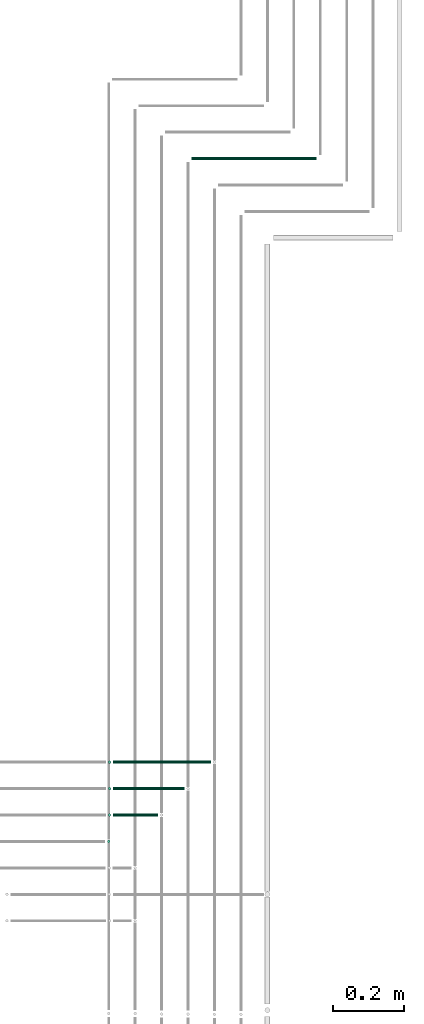
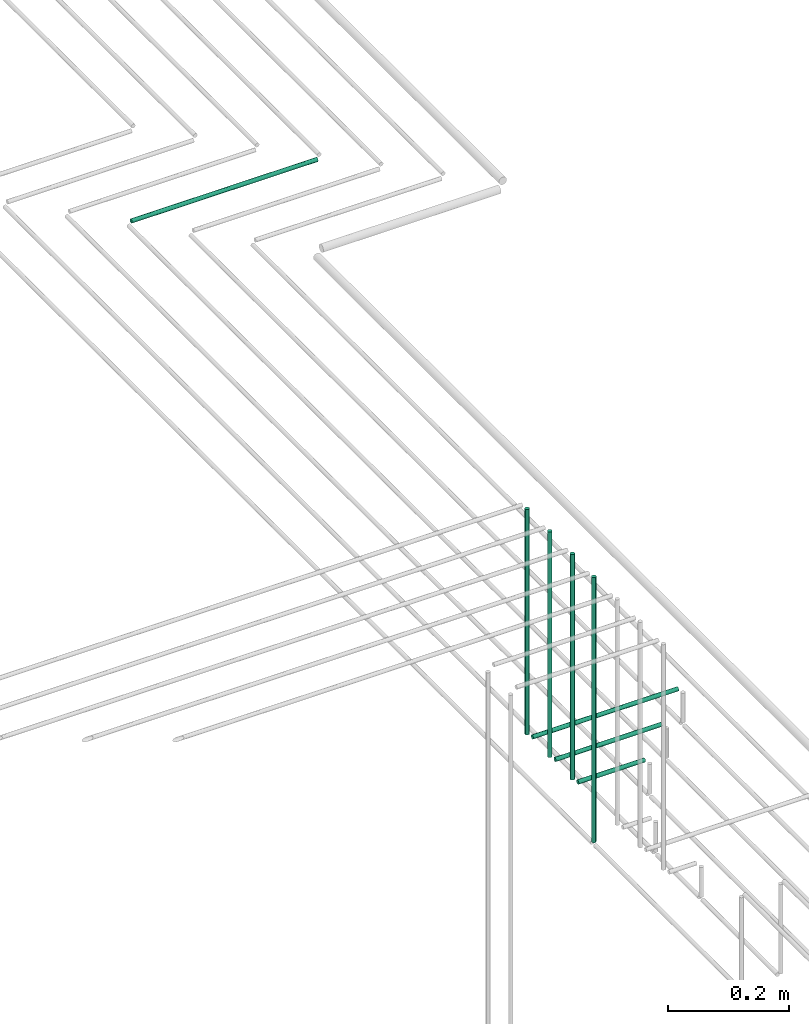
# One storey, part 51 of 89: 8 flow segments.
"""IFC2X3 building model written with IfcOpenShell, lengths in millimetres."""

from ifc_helpers import new_model, entity, si_unit, converted_unit, derived_unit, direction, frame, frame_2d, origin, origin_2d_with_axis, place, context, subcontext, project, spatial, circle, extrude, type_object, element, save


model = new_model("IFC2X3")

# Units and contexts
model_context = context("Model", 3, precision=0.01, world=origin(), true_north=direction((6.12303176911189e-17, 1.0)))
body_context = subcontext(model_context, "Body", "Model", "MODEL_VIEW")
ifc_project = project(units=[si_unit("LENGTHUNIT", "METRE", prefix="MILLI"), si_unit("AREAUNIT", "SQUARE_METRE"), si_unit("VOLUMEUNIT", "CUBIC_METRE"), converted_unit("PLANEANGLEUNIT", "DEGREE", entity("IfcRatioMeasure", 0.0174532925199433), si_unit("PLANEANGLEUNIT", "RADIAN"), dimensions=[0, 0, 0, 0, 0, 0, 0]), si_unit("MASSUNIT", "GRAM", prefix="KILO"), derived_unit("MASSDENSITYUNIT", [(si_unit("MASSUNIT", "GRAM", prefix="KILO"), 1), (si_unit("LENGTHUNIT", "METRE"), -3)]), derived_unit("MOMENTOFINERTIAUNIT", [(si_unit("LENGTHUNIT", "METRE"), 4)]), si_unit("TIMEUNIT", "SECOND"), si_unit("FREQUENCYUNIT", "HERTZ"), si_unit("THERMODYNAMICTEMPERATUREUNIT", "DEGREE_CELSIUS"), derived_unit("THERMALTRANSMITTANCEUNIT", [(si_unit("MASSUNIT", "GRAM", prefix="KILO"), 1), (si_unit("THERMODYNAMICTEMPERATUREUNIT", "KELVIN"), -1), (si_unit("TIMEUNIT", "SECOND"), -3)]), derived_unit("VOLUMETRICFLOWRATEUNIT", [(si_unit("LENGTHUNIT", "METRE"), 3), (si_unit("TIMEUNIT", "SECOND"), -1)]), derived_unit("MASSFLOWRATEUNIT", [(si_unit("MASSUNIT", "GRAM", prefix="KILO"), 1), (si_unit("TIMEUNIT", "SECOND"), -1)]), derived_unit("ROTATIONALFREQUENCYUNIT", [(si_unit("TIMEUNIT", "SECOND"), -1)]), si_unit("ELECTRICCURRENTUNIT", "AMPERE"), si_unit("ELECTRICVOLTAGEUNIT", "VOLT"), si_unit("POWERUNIT", "WATT"), si_unit("FORCEUNIT", "NEWTON", prefix="KILO"), si_unit("ILLUMINANCEUNIT", "LUX"), si_unit("LUMINOUSFLUXUNIT", "LUMEN"), si_unit("LUMINOUSINTENSITYUNIT", "CANDELA"), derived_unit("USERDEFINED", [(si_unit("MASSUNIT", "GRAM", prefix="KILO"), -1), (si_unit("LENGTHUNIT", "METRE"), -2), (si_unit("TIMEUNIT", "SECOND"), 3), (si_unit("LUMINOUSFLUXUNIT", "LUMEN"), 1)]), derived_unit("LINEARVELOCITYUNIT", [(si_unit("LENGTHUNIT", "METRE"), 1), (si_unit("TIMEUNIT", "SECOND"), -1)]), si_unit("PRESSUREUNIT", "PASCAL"), derived_unit("USERDEFINED", [(si_unit("LENGTHUNIT", "METRE"), -2), (si_unit("MASSUNIT", "GRAM", prefix="KILO"), 1), (si_unit("TIMEUNIT", "SECOND"), -2)]), derived_unit("LINEARFORCEUNIT", [(si_unit("MASSUNIT", "GRAM", prefix="KILO"), 1), (si_unit("LENGTHUNIT", "METRE"), 1), (si_unit("TIMEUNIT", "SECOND"), -2), (si_unit("LENGTHUNIT", "METRE"), -1)]), derived_unit("PLANARFORCEUNIT", [(si_unit("MASSUNIT", "GRAM", prefix="KILO"), 1), (si_unit("LENGTHUNIT", "METRE"), 1), (si_unit("TIMEUNIT", "SECOND"), -2), (si_unit("LENGTHUNIT", "METRE"), -2)])], contexts=[model_context])

# Site, building, storey
site_placement = place(None, frame((0.0, -0.00077364408347762, 0.0)))
site = spatial("IfcSite", under=ifc_project, at=site_placement, CompositionType="ELEMENT")
building_placement = place(site_placement, origin())
building = spatial("IfcBuilding", under=site, at=building_placement, CompositionType="ELEMENT")
storey_placement = place(building_placement, frame((0.0, 0.0, 24000.0)))
storey = spatial("IfcBuildingStorey", under=building, at=storey_placement, CompositionType="ELEMENT", Elevation=24000.0)

# Flow segments
pipe_segment_type = type_object("IfcPipeSegmentType", PredefinedType="NOTDEFINED")
flow_segment_1_placement = place(storey_placement, frame((67214.4049963189, 5207.64530556804, 2605.0)))
element("IfcFlowSegment", 1, at=flow_segment_1_placement, inside=storey, type_object=pipe_segment_type, context=body_context, shape_type="SweptSolid", body=[
    extrude(circle(Radius=4.0, at=frame_2d((0.0, -1.08286712929839e-12), x_axis=(1.0, 0.0))), frame((5.59527223591499, 5.59527223591499, 0.0), z_axis=(0.0, 0.0, 1.0), x_axis=(-1.0, 0.0, 0.0)), (0.0, 0.0, 1.0), 535.000000000043),
])
flow_segment_2_placement = place(storey_placement, frame((67455.0002685548, 7144.40472776384, 2594.40472776409)))
element("IfcFlowSegment", 2, at=flow_segment_2_placement, inside=storey, type_object=pipe_segment_type, context=body_context, shape_type="SweptSolid", body=[
    extrude(circle(Radius=4.0, at=origin_2d_with_axis()), frame((0.0, 5.59527223591607, 5.59527223591499), z_axis=(1.0, 0.0, 0.0), x_axis=(0.0, -1.0, 0.0)), (0.0, 0.0, 1.0), 354.999999999997),
])
flow_segment_3_placement = place(storey_placement, frame((67232.4133322517, 5282.64530556805, 2669.40472776407)))
element("IfcFlowSegment", 3, at=flow_segment_3_placement, inside=storey, type_object=pipe_segment_type, context=body_context, shape_type="SweptSolid", body=[
    extrude(circle(Radius=4.0, at=frame_2d((-1.08286712929839e-12, 0.0), x_axis=(1.0, 0.0))), frame((0.0, 5.59527223591716, 5.59527223591499), z_axis=(1.0, 0.0, 0.0), x_axis=(0.0, 1.0, 0.0)), (0.0, 0.0, 1.0), 127.586936303121),
])
flow_segment_4_placement = place(storey_placement, frame((67232.4133322517, 5357.64530556806, 2669.40472776407)))
element("IfcFlowSegment", 4, at=flow_segment_4_placement, inside=storey, type_object=pipe_segment_type, context=body_context, shape_type="SweptSolid", body=[
    extrude(circle(Radius=4.0, at=origin_2d_with_axis()), frame((0.0, 5.59527223591607, 5.59527223591499), z_axis=(1.0, 0.0, 0.0), x_axis=(0.0, 1.0, 0.0)), (0.0, 0.0, 1.0), 202.586936303121),
])
flow_segment_5_placement = place(storey_placement, frame((67232.4133322517, 5432.64530556806, 2669.40472776407)))
element("IfcFlowSegment", 5, at=flow_segment_5_placement, inside=storey, type_object=pipe_segment_type, context=body_context, shape_type="SweptSolid", body=[
    extrude(circle(Radius=4.0, at=frame_2d((6.49720277579036e-12, 0.0), x_axis=(1.0, 0.0))), frame((0.0, 5.59527223592257, 5.59527223591499), z_axis=(1.0, 0.0, 0.0), x_axis=(0.0, 1.0, 0.0)), (0.0, 0.0, 1.0), 277.586936303121),
])
flow_segment_6_placement = place(storey_placement, frame((67216.8180600158, 5432.64530556806, 2685.0)))
element("IfcFlowSegment", 6, at=flow_segment_6_placement, inside=storey, type_object=pipe_segment_type, context=body_context, shape_type="SweptSolid", body=[
    extrude(circle(Radius=4.0, at=origin_2d_with_axis()), frame((5.59527223591499, 5.59527223591607, 0.0), z_axis=(0.0, 0.0, 1.0), x_axis=(-1.0, 0.0, 0.0)), (0.0, 0.0, 1.0), 455.000000000057),
])
flow_segment_7_placement = place(storey_placement, frame((67216.8180600158, 5357.64530556806, 2685.0)))
element("IfcFlowSegment", 7, at=flow_segment_7_placement, inside=storey, type_object=pipe_segment_type, context=body_context, shape_type="SweptSolid", body=[
    extrude(circle(Radius=4.0, at=frame_2d((0.0, -1.08286712929839e-12), x_axis=(1.0, 0.0))), frame((5.59527223591499, 5.59527223591499, 0.0), z_axis=(0.0, 0.0, 1.0), x_axis=(-1.0, 0.0, 0.0)), (0.0, 0.0, 1.0), 455.000000000057),
])
flow_segment_8_placement = place(storey_placement, frame((67216.8180600158, 5282.64530556805, 2685.0)))
element("IfcFlowSegment", 8, at=flow_segment_8_placement, inside=storey, type_object=pipe_segment_type, context=body_context, shape_type="SweptSolid", body=[
    extrude(circle(Radius=4.0, at=origin_2d_with_axis()), frame((5.59527223591499, 5.59527223591607, 0.0), z_axis=(0.0, 0.0, 1.0), x_axis=(-1.0, 0.0, 0.0)), (0.0, 0.0, 1.0), 455.000000000057),
])

save(model, "model.ifc")
